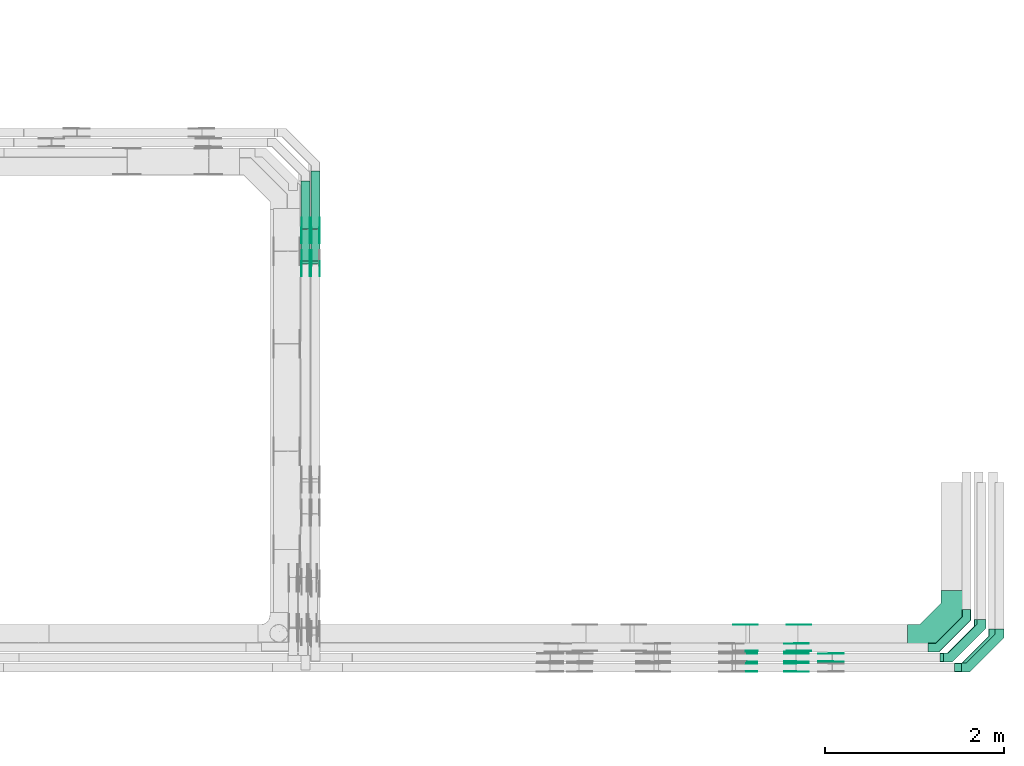
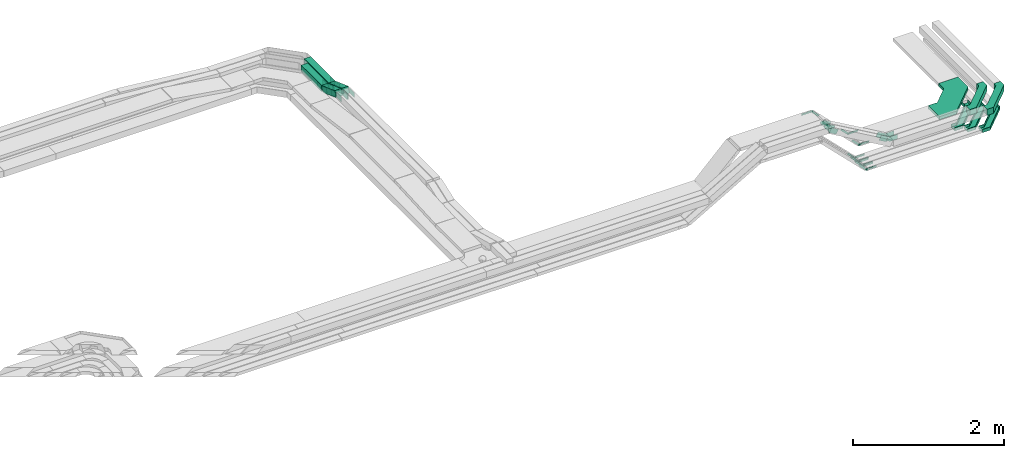
# One storey, part 27 of 32: 48 flow fittings, 4 flow segments.
"""IFC2X3 building model written with IfcOpenShell, lengths in millimetres."""

from ifc_helpers import new_model, entity, si_unit, converted_unit, derived_unit, direction, frame, frame_2d, origin, origin_2d_with_axis, place, context, subcontext, project, spatial, polyline, circle_curve, parameter, trimmed, segment, composite_curve, rectangle, outline, extrude, faceted_brep, source, transform, mapped, material, type_object, type_shapes, element, save


model = new_model("IFC2X3")

# Units and contexts
model_context = context("Model", 3, precision=0.01, world=origin(), true_north=direction((6.12303176911189e-17, 1.0)))
body_context = subcontext(model_context, "Body", "Model", "MODEL_VIEW")
ifc_project = project(units=[si_unit("LENGTHUNIT", "METRE", prefix="MILLI"), si_unit("AREAUNIT", "SQUARE_METRE"), si_unit("VOLUMEUNIT", "CUBIC_METRE"), converted_unit("PLANEANGLEUNIT", "DEGREE", entity("IfcRatioMeasure", 0.0174532925199433), si_unit("PLANEANGLEUNIT", "RADIAN"), dimensions=[0, 0, 0, 0, 0, 0, 0]), si_unit("MASSUNIT", "GRAM", prefix="KILO"), derived_unit("MASSDENSITYUNIT", [(si_unit("MASSUNIT", "GRAM", prefix="KILO"), 1), (si_unit("LENGTHUNIT", "METRE"), -3)]), derived_unit("MOMENTOFINERTIAUNIT", [(si_unit("LENGTHUNIT", "METRE"), 4)]), si_unit("TIMEUNIT", "SECOND"), si_unit("FREQUENCYUNIT", "HERTZ"), si_unit("THERMODYNAMICTEMPERATUREUNIT", "DEGREE_CELSIUS"), derived_unit("THERMALTRANSMITTANCEUNIT", [(si_unit("MASSUNIT", "GRAM", prefix="KILO"), 1), (si_unit("THERMODYNAMICTEMPERATUREUNIT", "KELVIN"), -1), (si_unit("TIMEUNIT", "SECOND"), -3)]), derived_unit("VOLUMETRICFLOWRATEUNIT", [(si_unit("LENGTHUNIT", "METRE"), 3), (si_unit("TIMEUNIT", "SECOND"), -1)]), derived_unit("MASSFLOWRATEUNIT", [(si_unit("MASSUNIT", "GRAM", prefix="KILO"), 1), (si_unit("TIMEUNIT", "SECOND"), -1)]), derived_unit("ROTATIONALFREQUENCYUNIT", [(si_unit("TIMEUNIT", "SECOND"), -1)]), si_unit("ELECTRICCURRENTUNIT", "AMPERE"), si_unit("ELECTRICVOLTAGEUNIT", "VOLT"), si_unit("POWERUNIT", "WATT"), si_unit("FORCEUNIT", "NEWTON", prefix="KILO"), si_unit("ILLUMINANCEUNIT", "LUX"), si_unit("LUMINOUSFLUXUNIT", "LUMEN"), si_unit("LUMINOUSINTENSITYUNIT", "CANDELA"), derived_unit("USERDEFINED", [(si_unit("MASSUNIT", "GRAM", prefix="KILO"), -1), (si_unit("LENGTHUNIT", "METRE"), -2), (si_unit("TIMEUNIT", "SECOND"), 3), (si_unit("LUMINOUSFLUXUNIT", "LUMEN"), 1)]), derived_unit("LINEARVELOCITYUNIT", [(si_unit("LENGTHUNIT", "METRE"), 1), (si_unit("TIMEUNIT", "SECOND"), -1)]), si_unit("PRESSUREUNIT", "PASCAL"), derived_unit("USERDEFINED", [(si_unit("LENGTHUNIT", "METRE"), -2), (si_unit("MASSUNIT", "GRAM", prefix="KILO"), 1), (si_unit("TIMEUNIT", "SECOND"), -2)]), derived_unit("LINEARFORCEUNIT", [(si_unit("MASSUNIT", "GRAM", prefix="KILO"), 1), (si_unit("LENGTHUNIT", "METRE"), 1), (si_unit("TIMEUNIT", "SECOND"), -2), (si_unit("LENGTHUNIT", "METRE"), -1)]), derived_unit("PLANARFORCEUNIT", [(si_unit("MASSUNIT", "GRAM", prefix="KILO"), 1), (si_unit("LENGTHUNIT", "METRE"), 1), (si_unit("TIMEUNIT", "SECOND"), -2), (si_unit("LENGTHUNIT", "METRE"), -2)])], contexts=[model_context])

# Site, building, storey
site_placement = place(None, origin())
site = spatial("IfcSite", under=ifc_project, at=site_placement, CompositionType="ELEMENT")
building_placement = place(site_placement, origin())
building = spatial("IfcBuilding", under=site, at=building_placement, CompositionType="ELEMENT")
storey_placement = place(building_placement, frame((0.0, 0.0, 8100.0)))
storey = spatial("IfcBuildingStorey", under=building, at=storey_placement, CompositionType="ELEMENT", Elevation=8100.0)

# Flow segments
cable_carrier_segment_type = type_object("IfcCableCarrierSegmentType", PredefinedType="CABLETRAYSEGMENT")
flow_segment_1_placement = place(storey_placement, frame((60610.11, 13576.56, 2715.06)))
element("IfcFlowSegment", 1, at=flow_segment_1_placement, inside=storey, type_object=cable_carrier_segment_type, context=body_context, shape_type="SweptSolid", body=[
    extrude(rectangle(XDim=539.716387424886, YDim=99.9999999999946, at=origin_2d_with_axis()), frame((50.0, 269.86, 0.0), z_axis=(0.0, 0.0, 1.0), x_axis=(0.0, 1.0, 0.0)), (0.0, 0.0, 1.0), 100.000000000001),
])
flow_segment_2_placement = place(storey_placement, frame((60720.11, 13576.56, 2715.06)))
element("IfcFlowSegment", 2, at=flow_segment_2_placement, inside=storey, type_object=cable_carrier_segment_type, context=body_context, shape_type="SweptSolid", body=[
    extrude(rectangle(XDim=649.712946592026, YDim=99.9999999999946, at=origin_2d_with_axis()), frame((50.0, 324.86, 0.01), z_axis=(0.0, -3.35252266217634e-05, 1.0), x_axis=(0.0, 1.0, 3.35252266217634e-05)), (0.0, 0.0, 1.0), 99.9999999999995),
])
flow_segment_3_placement = place(storey_placement, frame((60610.11, 13187.92, 2721.68)))
element("IfcFlowSegment", 3, at=flow_segment_3_placement, inside=storey, type_object=cable_carrier_segment_type, context=body_context, shape_type="SweptSolid", body=[
    extrude(rectangle(XDim=99.9999999999998, YDim=99.9999999999946, at=frame_2d((0.0, 0.0), x_axis=(0.0, 1.0))), frame((50.0, 17.1, 174.79), z_axis=(0.0, 0.939692620785896, -0.342020143325703), x_axis=(-1.0, 0.0, 0.0)), (0.0, 0.0, 1.0), 373.670280105611),
])
flow_segment_4_placement = place(storey_placement, frame((60720.11, 13187.92, 2721.68)))
element("IfcFlowSegment", 4, at=flow_segment_4_placement, inside=storey, type_object=cable_carrier_segment_type, context=body_context, shape_type="SweptSolid", body=[
    extrude(rectangle(XDim=99.9999996016359, YDim=99.9999996016381, at=frame_2d((0.0, 0.0), x_axis=(0.0, 1.0))), frame((50.0, 17.11, 174.82), z_axis=(0.0, 0.939662088474048, -0.342104018515701), x_axis=(-1.0, 0.0, 0.0)), (0.0, 0.0, 1.0), 373.674257558546),
])

# Flow fittings
ifc_material_1 = material()
cable_carrier_fitting_type_1 = type_object("IfcCableCarrierFittingType", Name="470_DKC_G5_Sheet horizontal bend:-", PredefinedType="NOTDEFINED", material=ifc_material_1)
shared_shape_1 = source(origin(), body_context, "Body", "SweptSolid", [
    extrude(outline(polyline([(-313.25, -362.75), (-50.12, -362.75), (362.75, 50.12), (362.75, 313.25), (62.75, 313.25), (62.75, 174.38), (-174.38, -62.75), (-313.25, -62.75), (-313.25, -362.75)])), frame((-212.75, 212.75, -25.0)), (0.0, 0.0, 1.0), 50.0000000000003),
])
type_shapes(cable_carrier_fitting_type_1, [shared_shape_1])
flow_fitting_1_placement = place(storey_placement, frame((67897.19, 9019.98, 2767.0)))
element("IfcFlowFitting", 5, at=flow_fitting_1_placement, inside=storey, type_object=cable_carrier_fitting_type_1, material=ifc_material_1, Name="470_DKC_G5_Sheet horizontal bend:-", ObjectType="470_DKC_G5_Sheet horizontal bend:-", context=body_context, shape_type="MappedRepresentation", body=[
    mapped(shared_shape_1, transform((0.0, 0.0, 0.0), scale=1.0)),
])
cable_carrier_fitting_type_2 = type_object("IfcCableCarrierFittingType", Name="470_DKC_G5_Sheet horizontal bend:-", PredefinedType="NOTDEFINED", material=ifc_material_1)
shared_shape_2 = source(origin(), body_context, "Body", "SweptSolid", [
    extrude(outline(polyline([(-232.0, -244.0), (-135.29, -244.0), (244.0, 135.29), (244.0, 232.0), (144.0, 232.0), (144.0, 176.71), (-176.71, -144.0), (-232.0, -144.0), (-232.0, -244.0)])), frame((-194.0, 194.0, -50.0)), (0.0, 0.0, 1.0), 100.0),
])
type_shapes(cable_carrier_fitting_type_2, [shared_shape_2])
for number, where, name in (
    (6, (68397.19, 8689.98, 2792.0), "470_DKC_G5_Sheet horizontal bend:-"),
    (7, (68197.19, 8799.98, 2792.0), "470_DKC_G5_Sheet horizontal bend:-"),
):
    element("IfcFlowFitting", number, at=place(storey_placement, frame(where)), inside=storey, type_object=cable_carrier_fitting_type_2, material=ifc_material_1, Name=name, ObjectType="470_DKC_G5_Sheet horizontal bend:-", context=body_context, shape_type="MappedRepresentation", body=[
        mapped(shared_shape_2, transform((0.0, 0.0, 0.0), scale=1.0)),
    ])
cable_carrier_fitting_type_3 = type_object("IfcCableCarrierFittingType", Name="470_DKC_G5_Sheet horizontal bend:-", PredefinedType="NOTDEFINED", material=ifc_material_1)
shared_shape_3 = source(origin(), body_context, "Body", "Brep", [
    faceted_brep([(-426.0, -50.0, -25.0), (-426.0, -50.0, 25.0), (-426.0, -45.0, 25.0), (-426.0, -45.0, -20.0), (-426.0, 45.0, -20.0), (-426.0, 45.0, 25.0), (-426.0, 50.0, 25.0), (-426.0, 50.0, -25.0), (50.0, 426.0, -25.0), (-50.0, 426.0, -25.0), (-50.0, 426.0, 25.0), (-45.0, 426.0, 25.0), (-45.0, 426.0, -20.0), (45.0, 426.0, -20.0), (45.0, 426.0, 25.0), (50.0, 426.0, 25.0), (-304.29, -50.0, -25.0), (-304.29, -50.0, 25.0), (50.0, 304.29, 25.0), (45.0, 306.36, 25.0), (-306.36, -45.0, 25.0), (-306.36, -45.0, -20.0), (45.0, 306.36, -20.0), (-45.0, 343.64, -20.0), (-343.64, 45.0, -20.0), (-343.64, 45.0, 25.0), (-45.0, 343.64, 25.0), (-50.0, 345.71, 25.0), (-345.71, 50.0, 25.0), (-345.71, 50.0, -25.0), (-50.0, 345.71, -25.0), (50.0, 304.29, -25.0)], [[[0, 1, 2, 3, 4, 5, 6, 7]], [[8, 9, 10, 11, 12, 13, 14, 15]], [[1, 0, 16, 17]], [[2, 1, 17, 18, 15, 14, 19, 20]], [[3, 2, 20, 21]], [[4, 3, 21, 22, 13, 12, 23, 24]], [[5, 4, 24, 25]], [[6, 5, 25, 26, 11, 10, 27, 28]], [[7, 6, 28, 29]], [[0, 7, 29, 30, 9, 8, 31, 16]], [[17, 16, 31, 18]], [[21, 20, 19, 22]], [[25, 24, 23, 26]], [[29, 28, 27, 30]], [[18, 31, 8, 15]], [[22, 19, 14, 13]], [[26, 23, 12, 11]], [[30, 27, 10, 9]]]),
])
type_shapes(cable_carrier_fitting_type_3, [shared_shape_3])
for number, where, name in (
    (8, (68027.71, 8909.98, 2514.2), "470_DKC_G5_Sheet horizontal bend:-"),
    (9, (68161.51, 8799.98, 2514.2), "470_DKC_G5_Sheet horizontal bend:-"),
    (10, (68323.1, 8689.98, 2514.2), "470_DKC_G5_Sheet horizontal bend:-"),
):
    element("IfcFlowFitting", number, at=place(storey_placement, frame(where)), inside=storey, type_object=cable_carrier_fitting_type_3, material=ifc_material_1, Name=name, ObjectType="470_DKC_G5_Sheet horizontal bend:-", context=body_context, shape_type="MappedRepresentation", body=[
        mapped(shared_shape_3, transform((0.0, 0.0, 0.0), scale=1.0)),
    ])
ifc_material_2 = material(Name="G")
cable_carrier_fitting_type_4 = type_object("IfcCableCarrierFittingType", PredefinedType="NOTDEFINED", material=ifc_material_2)
shared_shape_4 = source(origin(), body_context, "Body", "SweptSolid", [
    extrude(outline(composite_curve([segment(trimmed(circle_curve(frame_2d((-44.59, 0.0), x_axis=(1.0, 0.0)), 12.5), [parameter(90.0000000000007)], [parameter(270.0)], True, "PARAMETER"), True, "CONTINUOUS"), segment(polyline([(-44.59, -12.5), (-33.09, -12.5)]), True, "CONTINUOUS"), segment(polyline([(-33.09, -12.5), (-31.23, -14.5)]), True, "CONTINUOUS"), segment(polyline([(-31.23, -14.5), (108.91, -14.5)]), True, "CONTINUOUS"), segment(polyline([(108.91, -14.5), (108.91, 14.5)]), True, "CONTINUOUS"), segment(polyline([(108.91, 14.5), (-31.23, 14.5)]), True, "CONTINUOUS"), segment(polyline([(-31.23, 14.5), (-33.09, 12.5)]), True, "CONTINUOUS"), segment(polyline([(-33.09, 12.5), (-44.59, 12.5)]), True, "CONTINUOUS")], self_intersect=False)), frame((44.59, 0.0, 0.0), z_axis=(0.0, 0.0, -1.0), x_axis=(1.0, 0.0, 0.0)), (0.0, 0.0, -1.0), 2.0),
])
type_shapes(cable_carrier_fitting_type_4, [shared_shape_4])
for number, where, z_axis, x_axis in (
    (11, (65581.99, 9165.44, 3327.15), (0.0, 1.0, 0.0), (0.707106781186591, 0.0, -0.707106781186504)),
    (12, (66118.46, 8864.52, 2514.2), (0.0, -1.0, 0.0), (1.0, 0.0, 0.0)),
):
    element("IfcFlowFitting", number, at=place(storey_placement, frame(where, z_axis=z_axis, x_axis=x_axis)), inside=storey, type_object=cable_carrier_fitting_type_4, material=ifc_material_2, context=body_context, shape_type="MappedRepresentation", body=[
        mapped(shared_shape_4, transform((0.0, 0.0, 0.0), scale=1.0)),
    ])
cable_carrier_fitting_type_5 = type_object("IfcCableCarrierFittingType", PredefinedType="NOTDEFINED", material=ifc_material_2)
type_shapes(cable_carrier_fitting_type_5, [shared_shape_4])
flow_fitting_2_placement = place(storey_placement, frame((66118.46, 8953.44, 2514.2), z_axis=(0.0, 1.0, 0.0), x_axis=(-0.707106781186547, 0.0, 0.707106781186548)))
element("IfcFlowFitting", 13, at=flow_fitting_2_placement, inside=storey, type_object=cable_carrier_fitting_type_5, material=ifc_material_2, context=body_context, shape_type="MappedRepresentation", body=[
    mapped(shared_shape_4, transform((0.0, 0.0, 0.0), scale=1.0)),
])
flow_fitting_3_placement = place(storey_placement, frame((66118.46, 8754.52, 2514.2), z_axis=(0.0, -1.0, 0.0), x_axis=(1.0, 0.0, 0.0)))
element("IfcFlowFitting", 14, at=flow_fitting_3_placement, inside=storey, type_object=cable_carrier_fitting_type_4, material=ifc_material_2, context=body_context, shape_type="MappedRepresentation", body=[
    mapped(shared_shape_4, transform((0.0, 0.0, 0.0), scale=1.0)),
])
flow_fitting_4_placement = place(storey_placement, frame((66118.46, 8843.44, 2514.2), z_axis=(0.0, 1.0, 0.0), x_axis=(-0.707106781186549, 0.0, 0.707106781186547)))
element("IfcFlowFitting", 15, at=flow_fitting_4_placement, inside=storey, type_object=cable_carrier_fitting_type_5, material=ifc_material_2, context=body_context, shape_type="MappedRepresentation", body=[
    mapped(shared_shape_4, transform((0.0, 0.0, 0.0), scale=1.0)),
])
flow_fitting_5_placement = place(storey_placement, frame((66118.46, 8644.52, 2514.2), z_axis=(0.0, -1.0, 0.0), x_axis=(1.0, 0.0, 0.0)))
element("IfcFlowFitting", 16, at=flow_fitting_5_placement, inside=storey, type_object=cable_carrier_fitting_type_4, material=ifc_material_2, context=body_context, shape_type="MappedRepresentation", body=[
    mapped(shared_shape_4, transform((0.0, 0.0, 0.0), scale=1.0)),
])
flow_fitting_6_placement = place(storey_placement, frame((66118.46, 8733.44, 2514.2), z_axis=(0.0, 1.0, 0.0), x_axis=(-0.707106781186497, 0.0, 0.707106781186598)))
element("IfcFlowFitting", 17, at=flow_fitting_6_placement, inside=storey, type_object=cable_carrier_fitting_type_5, material=ifc_material_2, context=body_context, shape_type="MappedRepresentation", body=[
    mapped(shared_shape_4, transform((0.0, 0.0, 0.0), scale=1.0)),
])
flow_fitting_7_placement = place(storey_placement, frame((66142.14, 8874.52, 2767.0), z_axis=(0.0, -1.0, 0.0), x_axis=(1.0, 0.0, 0.0)))
element("IfcFlowFitting", 18, at=flow_fitting_7_placement, inside=storey, type_object=cable_carrier_fitting_type_4, material=ifc_material_2, context=body_context, shape_type="MappedRepresentation", body=[
    mapped(shared_shape_4, transform((0.0, 0.0, 0.0), scale=1.0)),
])
flow_fitting_8_placement = place(storey_placement, frame((66142.14, 9163.44, 2767.0), z_axis=(0.0, 1.0, 0.0), x_axis=(-0.707106781186539, 0.0, 0.707106781186556)))
element("IfcFlowFitting", 19, at=flow_fitting_8_placement, inside=storey, type_object=cable_carrier_fitting_type_5, material=ifc_material_2, context=body_context, shape_type="MappedRepresentation", body=[
    mapped(shared_shape_4, transform((0.0, 0.0, 0.0), scale=1.0)),
])
cable_carrier_fitting_type_6 = type_object("IfcCableCarrierFittingType", PredefinedType="NOTDEFINED", material=ifc_material_2)
shared_shape_5 = source(origin(), body_context, "Body", "SweptSolid", [
    extrude(outline(composite_curve([segment(trimmed(circle_curve(frame_2d((-44.59, 0.0), x_axis=(1.0, 0.0)), 12.5), [parameter(90.0000000000007)], [parameter(270.0)], True, "PARAMETER"), True, "CONTINUOUS"), segment(polyline([(-44.59, -12.5), (-33.09, -12.5)]), True, "CONTINUOUS"), segment(polyline([(-33.09, -12.5), (-31.23, -14.5)]), True, "CONTINUOUS"), segment(polyline([(-31.23, -14.5), (108.91, -14.5)]), True, "CONTINUOUS"), segment(polyline([(108.91, -14.5), (108.91, 14.5)]), True, "CONTINUOUS"), segment(polyline([(108.91, 14.5), (-31.23, 14.5)]), True, "CONTINUOUS"), segment(polyline([(-31.23, 14.5), (-33.09, 12.5)]), True, "CONTINUOUS"), segment(polyline([(-33.09, 12.5), (-44.59, 12.5)]), True, "CONTINUOUS")], self_intersect=False)), frame((44.59, 0.0, 0.0)), (0.0, 0.0, 1.0), 2.0),
])
type_shapes(cable_carrier_fitting_type_6, [shared_shape_5])
flow_fitting_9_placement = place(storey_placement, frame((65581.99, 8874.52, 3327.15), z_axis=(0.0, -1.0, 0.0), x_axis=(0.707106781186591, 0.0, -0.707106781186504)))
element("IfcFlowFitting", 20, at=flow_fitting_9_placement, inside=storey, type_object=cable_carrier_fitting_type_6, material=ifc_material_2, context=body_context, shape_type="MappedRepresentation", body=[
    mapped(shared_shape_5, transform((0.0, 0.0, 0.0), scale=1.0)),
])
cable_carrier_fitting_type_7 = type_object("IfcCableCarrierFittingType", PredefinedType="NOTDEFINED", material=ifc_material_2)
type_shapes(cable_carrier_fitting_type_7, [shared_shape_5])
flow_fitting_10_placement = place(storey_placement, frame((65581.99, 9163.44, 3327.15), z_axis=(0.0, 1.0, 0.0), x_axis=(-1.0, 0.0, 0.0)))
element("IfcFlowFitting", 21, at=flow_fitting_10_placement, inside=storey, type_object=cable_carrier_fitting_type_7, material=ifc_material_2, context=body_context, shape_type="MappedRepresentation", body=[
    mapped(shared_shape_5, transform((0.0, 0.0, 0.0), scale=1.0)),
])
flow_fitting_11_placement = place(storey_placement, frame((66118.46, 8955.44, 2514.2), z_axis=(0.0, 1.0, 0.0), x_axis=(1.0, 0.0, 0.0)))
element("IfcFlowFitting", 22, at=flow_fitting_11_placement, inside=storey, type_object=cable_carrier_fitting_type_6, material=ifc_material_2, context=body_context, shape_type="MappedRepresentation", body=[
    mapped(shared_shape_5, transform((0.0, 0.0, 0.0), scale=1.0)),
])
flow_fitting_12_placement = place(storey_placement, frame((66118.46, 8866.52, 2514.2), z_axis=(0.0, -1.0, 0.0), x_axis=(-0.707106781186547, 0.0, 0.707106781186548)))
element("IfcFlowFitting", 23, at=flow_fitting_12_placement, inside=storey, type_object=cable_carrier_fitting_type_7, material=ifc_material_2, context=body_context, shape_type="MappedRepresentation", body=[
    mapped(shared_shape_5, transform((0.0, 0.0, 0.0), scale=1.0)),
])
flow_fitting_13_placement = place(storey_placement, frame((66118.46, 8845.44, 2514.2), z_axis=(0.0, 1.0, 0.0), x_axis=(1.0, 0.0, 0.0)))
element("IfcFlowFitting", 24, at=flow_fitting_13_placement, inside=storey, type_object=cable_carrier_fitting_type_6, material=ifc_material_2, context=body_context, shape_type="MappedRepresentation", body=[
    mapped(shared_shape_5, transform((0.0, 0.0, 0.0), scale=1.0)),
])
flow_fitting_14_placement = place(storey_placement, frame((66118.46, 8756.52, 2514.2), z_axis=(0.0, -1.0, 0.0), x_axis=(-0.707106781186549, 0.0, 0.707106781186547)))
element("IfcFlowFitting", 25, at=flow_fitting_14_placement, inside=storey, type_object=cable_carrier_fitting_type_7, material=ifc_material_2, context=body_context, shape_type="MappedRepresentation", body=[
    mapped(shared_shape_5, transform((0.0, 0.0, 0.0), scale=1.0)),
])
flow_fitting_15_placement = place(storey_placement, frame((66118.46, 8735.44, 2514.2), z_axis=(0.0, 1.0, 0.0), x_axis=(1.0, 0.0, 0.0)))
element("IfcFlowFitting", 26, at=flow_fitting_15_placement, inside=storey, type_object=cable_carrier_fitting_type_6, material=ifc_material_2, context=body_context, shape_type="MappedRepresentation", body=[
    mapped(shared_shape_5, transform((0.0, 0.0, 0.0), scale=1.0)),
])
flow_fitting_16_placement = place(storey_placement, frame((66118.46, 8646.52, 2514.2), z_axis=(0.0, -1.0, 0.0), x_axis=(-0.707106781186497, 0.0, 0.707106781186598)))
element("IfcFlowFitting", 27, at=flow_fitting_16_placement, inside=storey, type_object=cable_carrier_fitting_type_7, material=ifc_material_2, context=body_context, shape_type="MappedRepresentation", body=[
    mapped(shared_shape_5, transform((0.0, 0.0, 0.0), scale=1.0)),
])
flow_fitting_17_placement = place(storey_placement, frame((66142.14, 9165.44, 2767.0), z_axis=(0.0, 1.0, 0.0), x_axis=(1.0, 0.0, 0.0)))
element("IfcFlowFitting", 28, at=flow_fitting_17_placement, inside=storey, type_object=cable_carrier_fitting_type_6, material=ifc_material_2, context=body_context, shape_type="MappedRepresentation", body=[
    mapped(shared_shape_5, transform((0.0, 0.0, 0.0), scale=1.0)),
])
flow_fitting_18_placement = place(storey_placement, frame((66142.14, 8876.52, 2767.0), z_axis=(0.0, -1.0, 0.0), x_axis=(-0.707106781186539, 0.0, 0.707106781186556)))
element("IfcFlowFitting", 29, at=flow_fitting_18_placement, inside=storey, type_object=cable_carrier_fitting_type_7, material=ifc_material_2, context=body_context, shape_type="MappedRepresentation", body=[
    mapped(shared_shape_5, transform((0.0, 0.0, 0.0), scale=1.0)),
])
cable_carrier_fitting_type_8 = type_object("IfcCableCarrierFittingType", PredefinedType="NOTDEFINED", material=ifc_material_2)
shared_shape_6 = source(origin(), body_context, "Body", "SweptSolid", [
    extrude(outline(composite_curve([segment(trimmed(circle_curve(frame_2d((-41.47, 0.0), x_axis=(1.0, 0.0)), 25.0), [parameter(90.0000000000007)], [parameter(270.0)], True, "PARAMETER"), True, "CONTINUOUS"), segment(polyline([(-41.47, -25.0), (-29.97, -25.0)]), True, "CONTINUOUS"), segment(polyline([(-29.97, -25.0), (-28.1, -38.5)]), True, "CONTINUOUS"), segment(polyline([(-28.1, -38.5), (99.53, -38.5)]), True, "CONTINUOUS"), segment(polyline([(99.53, -38.5), (99.53, 38.5)]), True, "CONTINUOUS"), segment(polyline([(99.53, 38.5), (-28.1, 38.5)]), True, "CONTINUOUS"), segment(polyline([(-28.1, 38.5), (-29.97, 25.0)]), True, "CONTINUOUS"), segment(polyline([(-29.97, 25.0), (-41.47, 25.0)]), True, "CONTINUOUS")], self_intersect=False)), frame((41.47, 0.0, 0.0), z_axis=(0.0, 0.0, -1.0), x_axis=(1.0, 0.0, 0.0)), (0.0, 0.0, -1.0), 2.0),
])
type_shapes(cable_carrier_fitting_type_8, [shared_shape_6])
flow_fitting_19_placement = place(storey_placement, frame((60614.65, 13566.04, 2765.06), z_axis=(-1.0, 0.0, 0.0), x_axis=(0.0, -0.939692620785909, 0.342020143325668)))
element("IfcFlowFitting", 30, at=flow_fitting_19_placement, inside=storey, type_object=cable_carrier_fitting_type_8, material=ifc_material_2, context=body_context, shape_type="MappedRepresentation", body=[
    mapped(shared_shape_6, transform((0.0, 0.0, 0.0), scale=1.0)),
])
cable_carrier_fitting_type_9 = type_object("IfcCableCarrierFittingType", PredefinedType="NOTDEFINED", material=ifc_material_2)
type_shapes(cable_carrier_fitting_type_9, [shared_shape_6])
flow_fitting_20_placement = place(storey_placement, frame((60703.57, 13566.04, 2765.06), z_axis=(1.0, 0.0, 0.0), x_axis=(0.0, 1.0, 0.0)))
element("IfcFlowFitting", 31, at=flow_fitting_20_placement, inside=storey, type_object=cable_carrier_fitting_type_9, material=ifc_material_2, context=body_context, shape_type="MappedRepresentation", body=[
    mapped(shared_shape_6, transform((0.0, 0.0, 0.0), scale=1.0)),
])
flow_fitting_21_placement = place(storey_placement, frame((60705.57, 13195.13, 2900.06), z_axis=(1.0, 0.0, 0.0), x_axis=(0.0, -1.0, 0.0)))
element("IfcFlowFitting", 32, at=flow_fitting_21_placement, inside=storey, type_object=cable_carrier_fitting_type_8, material=ifc_material_2, context=body_context, shape_type="MappedRepresentation", body=[
    mapped(shared_shape_6, transform((0.0, 0.0, 0.0), scale=1.0)),
])
flow_fitting_22_placement = place(storey_placement, frame((60616.65, 13195.13, 2900.06), z_axis=(-1.0, 0.0, 0.0), x_axis=(0.0, 0.939692620785898, -0.342020143325699)))
element("IfcFlowFitting", 33, at=flow_fitting_22_placement, inside=storey, type_object=cable_carrier_fitting_type_9, material=ifc_material_2, context=body_context, shape_type="MappedRepresentation", body=[
    mapped(shared_shape_6, transform((0.0, 0.0, 0.0), scale=1.0)),
])
flow_fitting_23_placement = place(storey_placement, frame((60815.57, 13566.04, 2765.06), z_axis=(1.0, 0.0, 0.0), x_axis=(0.0, 1.0, 3.43565421406233e-05)))
element("IfcFlowFitting", 34, at=flow_fitting_23_placement, inside=storey, type_object=cable_carrier_fitting_type_8, material=ifc_material_2, context=body_context, shape_type="MappedRepresentation", body=[
    mapped(shared_shape_6, transform((0.0, 0.0, 0.0), scale=1.0)),
])
flow_fitting_24_placement = place(storey_placement, frame((60726.65, 13566.04, 2765.06), z_axis=(-1.0, 0.0, 0.0), x_axis=(0.0, -0.939662088474059, 0.34210401851567)))
element("IfcFlowFitting", 35, at=flow_fitting_24_placement, inside=storey, type_object=cable_carrier_fitting_type_9, material=ifc_material_2, context=body_context, shape_type="MappedRepresentation", body=[
    mapped(shared_shape_6, transform((0.0, 0.0, 0.0), scale=1.0)),
])
flow_fitting_25_placement = place(storey_placement, frame((60815.57, 13195.13, 2900.1), z_axis=(1.0, 0.0, 0.0), x_axis=(0.0, -1.0, 0.0)))
element("IfcFlowFitting", 36, at=flow_fitting_25_placement, inside=storey, type_object=cable_carrier_fitting_type_8, material=ifc_material_2, context=body_context, shape_type="MappedRepresentation", body=[
    mapped(shared_shape_6, transform((0.0, 0.0, 0.0), scale=1.0)),
])
flow_fitting_26_placement = place(storey_placement, frame((60726.65, 13195.13, 2900.1), z_axis=(-1.0, 0.0, 0.0), x_axis=(0.0, 0.939662088474052, -0.342104018515689)))
element("IfcFlowFitting", 37, at=flow_fitting_26_placement, inside=storey, type_object=cable_carrier_fitting_type_9, material=ifc_material_2, context=body_context, shape_type="MappedRepresentation", body=[
    mapped(shared_shape_6, transform((0.0, 0.0, 0.0), scale=1.0)),
])
flow_fitting_27_placement = place(storey_placement, frame((65554.1, 8845.44, 3349.35), z_axis=(0.0, 1.0, 0.0), x_axis=(0.866025403786882, 0.0, -0.499999999995767)))
element("IfcFlowFitting", 38, at=flow_fitting_27_placement, inside=storey, type_object=cable_carrier_fitting_type_8, material=ifc_material_2, context=body_context, shape_type="MappedRepresentation", body=[
    mapped(shared_shape_6, transform((0.0, 0.0, 0.0), scale=1.0)),
])
flow_fitting_28_placement = place(storey_placement, frame((65552.72, 8733.44, 3350.15), z_axis=(0.0, 1.0, 0.0), x_axis=(0.866025403784436, 0.0, -0.500000000000005)))
element("IfcFlowFitting", 39, at=flow_fitting_28_placement, inside=storey, type_object=cable_carrier_fitting_type_9, material=ifc_material_2, context=body_context, shape_type="MappedRepresentation", body=[
    mapped(shared_shape_6, transform((0.0, 0.0, 0.0), scale=1.0)),
])
flow_fitting_29_placement = place(storey_placement, frame((66519.46, 8754.52, 2792.0), z_axis=(0.0, -1.0, 0.0), x_axis=(1.0, 0.0, 0.0)))
element("IfcFlowFitting", 40, at=flow_fitting_29_placement, inside=storey, type_object=cable_carrier_fitting_type_8, material=ifc_material_2, context=body_context, shape_type="MappedRepresentation", body=[
    mapped(shared_shape_6, transform((0.0, 0.0, 0.0), scale=1.0)),
])
flow_fitting_30_placement = place(storey_placement, frame((66519.46, 8843.44, 2792.0), z_axis=(0.0, 1.0, 0.0), x_axis=(-0.866025403784435, 0.0, 0.500000000000007)))
element("IfcFlowFitting", 41, at=flow_fitting_30_placement, inside=storey, type_object=cable_carrier_fitting_type_9, material=ifc_material_2, context=body_context, shape_type="MappedRepresentation", body=[
    mapped(shared_shape_6, transform((0.0, 0.0, 0.0), scale=1.0)),
])
cable_carrier_fitting_type_10 = type_object("IfcCableCarrierFittingType", PredefinedType="NOTDEFINED", material=ifc_material_2)
shared_shape_7 = source(origin(), body_context, "Body", "SweptSolid", [
    extrude(outline(composite_curve([segment(trimmed(circle_curve(frame_2d((-41.47, 0.0), x_axis=(1.0, 0.0)), 25.0), [parameter(90.0000000000007)], [parameter(270.0)], True, "PARAMETER"), True, "CONTINUOUS"), segment(polyline([(-41.47, -25.0), (-29.97, -25.0)]), True, "CONTINUOUS"), segment(polyline([(-29.97, -25.0), (-28.1, -38.5)]), True, "CONTINUOUS"), segment(polyline([(-28.1, -38.5), (99.53, -38.5)]), True, "CONTINUOUS"), segment(polyline([(99.53, -38.5), (99.53, 38.5)]), True, "CONTINUOUS"), segment(polyline([(99.53, 38.5), (-28.1, 38.5)]), True, "CONTINUOUS"), segment(polyline([(-28.1, 38.5), (-29.97, 25.0)]), True, "CONTINUOUS"), segment(polyline([(-29.97, 25.0), (-41.47, 25.0)]), True, "CONTINUOUS")], self_intersect=False)), frame((41.47, 0.0, 0.0)), (0.0, 0.0, 1.0), 2.0),
])
type_shapes(cable_carrier_fitting_type_10, [shared_shape_7])
flow_fitting_31_placement = place(storey_placement, frame((60705.57, 13566.04, 2765.06), z_axis=(1.0, 0.0, 0.0), x_axis=(0.0, -0.939692620785909, 0.342020143325668)))
element("IfcFlowFitting", 42, at=flow_fitting_31_placement, inside=storey, type_object=cable_carrier_fitting_type_10, material=ifc_material_2, context=body_context, shape_type="MappedRepresentation", body=[
    mapped(shared_shape_7, transform((0.0, 0.0, 0.0), scale=1.0)),
])
cable_carrier_fitting_type_11 = type_object("IfcCableCarrierFittingType", PredefinedType="NOTDEFINED", material=ifc_material_2)
type_shapes(cable_carrier_fitting_type_11, [shared_shape_7])
flow_fitting_32_placement = place(storey_placement, frame((60616.65, 13566.04, 2765.06), z_axis=(-1.0, 0.0, 0.0), x_axis=(0.0, 1.0, 0.0)))
element("IfcFlowFitting", 43, at=flow_fitting_32_placement, inside=storey, type_object=cable_carrier_fitting_type_11, material=ifc_material_2, context=body_context, shape_type="MappedRepresentation", body=[
    mapped(shared_shape_7, transform((0.0, 0.0, 0.0), scale=1.0)),
])
flow_fitting_33_placement = place(storey_placement, frame((60614.65, 13195.13, 2900.06), z_axis=(-1.0, 0.0, 0.0), x_axis=(0.0, -1.0, 0.0)))
element("IfcFlowFitting", 44, at=flow_fitting_33_placement, inside=storey, type_object=cable_carrier_fitting_type_10, material=ifc_material_2, context=body_context, shape_type="MappedRepresentation", body=[
    mapped(shared_shape_7, transform((0.0, 0.0, 0.0), scale=1.0)),
])
flow_fitting_34_placement = place(storey_placement, frame((60703.57, 13195.13, 2900.06), z_axis=(1.0, 0.0, 0.0), x_axis=(0.0, 0.939692620785898, -0.342020143325699)))
element("IfcFlowFitting", 45, at=flow_fitting_34_placement, inside=storey, type_object=cable_carrier_fitting_type_11, material=ifc_material_2, context=body_context, shape_type="MappedRepresentation", body=[
    mapped(shared_shape_7, transform((0.0, 0.0, 0.0), scale=1.0)),
])
flow_fitting_35_placement = place(storey_placement, frame((60724.65, 13566.04, 2765.06), z_axis=(-1.0, 0.0, 0.0), x_axis=(0.0, 1.0, 3.43565421406233e-05)))
element("IfcFlowFitting", 46, at=flow_fitting_35_placement, inside=storey, type_object=cable_carrier_fitting_type_10, material=ifc_material_2, context=body_context, shape_type="MappedRepresentation", body=[
    mapped(shared_shape_7, transform((0.0, 0.0, 0.0), scale=1.0)),
])
flow_fitting_36_placement = place(storey_placement, frame((60813.57, 13566.04, 2765.06), z_axis=(1.0, 0.0, 0.0), x_axis=(0.0, -0.939662088474059, 0.34210401851567)))
element("IfcFlowFitting", 47, at=flow_fitting_36_placement, inside=storey, type_object=cable_carrier_fitting_type_11, material=ifc_material_2, context=body_context, shape_type="MappedRepresentation", body=[
    mapped(shared_shape_7, transform((0.0, 0.0, 0.0), scale=1.0)),
])
for number, where, z_axis, x_axis in (
    (48, (60724.65, 13195.13, 2900.1), (-1.0, 0.0, 0.0), (0.0, -1.0, 0.0)),
    (49, (65554.1, 8754.52, 3349.35), (0.0, -1.0, 0.0), (0.866025403786882, 0.0, -0.499999999995767)),
):
    element("IfcFlowFitting", number, at=place(storey_placement, frame(where, z_axis=z_axis, x_axis=x_axis)), inside=storey, type_object=cable_carrier_fitting_type_10, material=ifc_material_2, context=body_context, shape_type="MappedRepresentation", body=[
        mapped(shared_shape_7, transform((0.0, 0.0, 0.0), scale=1.0)),
    ])
flow_fitting_37_placement = place(storey_placement, frame((65552.72, 8646.52, 3350.15), z_axis=(0.0, -1.0, 0.0), x_axis=(0.866025403784436, 0.0, -0.500000000000005)))
element("IfcFlowFitting", 50, at=flow_fitting_37_placement, inside=storey, type_object=cable_carrier_fitting_type_11, material=ifc_material_2, context=body_context, shape_type="MappedRepresentation", body=[
    mapped(shared_shape_7, transform((0.0, 0.0, 0.0), scale=1.0)),
])
flow_fitting_38_placement = place(storey_placement, frame((66519.46, 8845.44, 2792.0), z_axis=(0.0, 1.0, 0.0), x_axis=(1.0, 0.0, 0.0)))
element("IfcFlowFitting", 51, at=flow_fitting_38_placement, inside=storey, type_object=cable_carrier_fitting_type_10, material=ifc_material_2, context=body_context, shape_type="MappedRepresentation", body=[
    mapped(shared_shape_7, transform((0.0, 0.0, 0.0), scale=1.0)),
])
flow_fitting_39_placement = place(storey_placement, frame((66519.46, 8756.52, 2792.0), z_axis=(0.0, -1.0, 0.0), x_axis=(-0.866025403784435, 0.0, 0.500000000000007)))
element("IfcFlowFitting", 52, at=flow_fitting_39_placement, inside=storey, type_object=cable_carrier_fitting_type_11, material=ifc_material_2, context=body_context, shape_type="MappedRepresentation", body=[
    mapped(shared_shape_7, transform((0.0, 0.0, 0.0), scale=1.0)),
])

save(model, "model.ifc")
